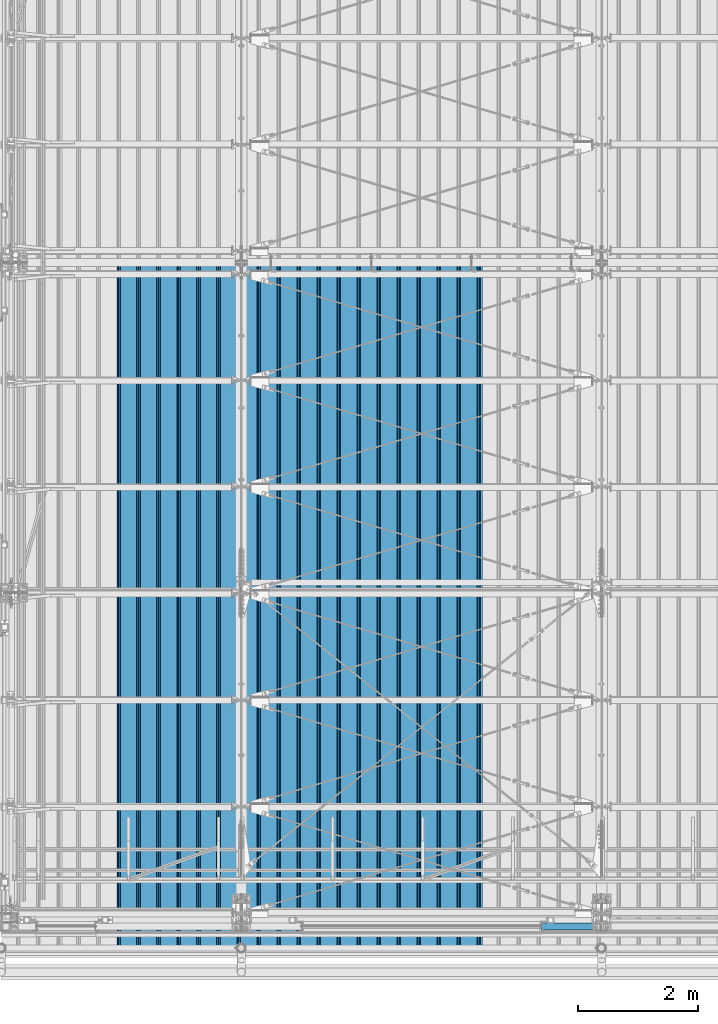
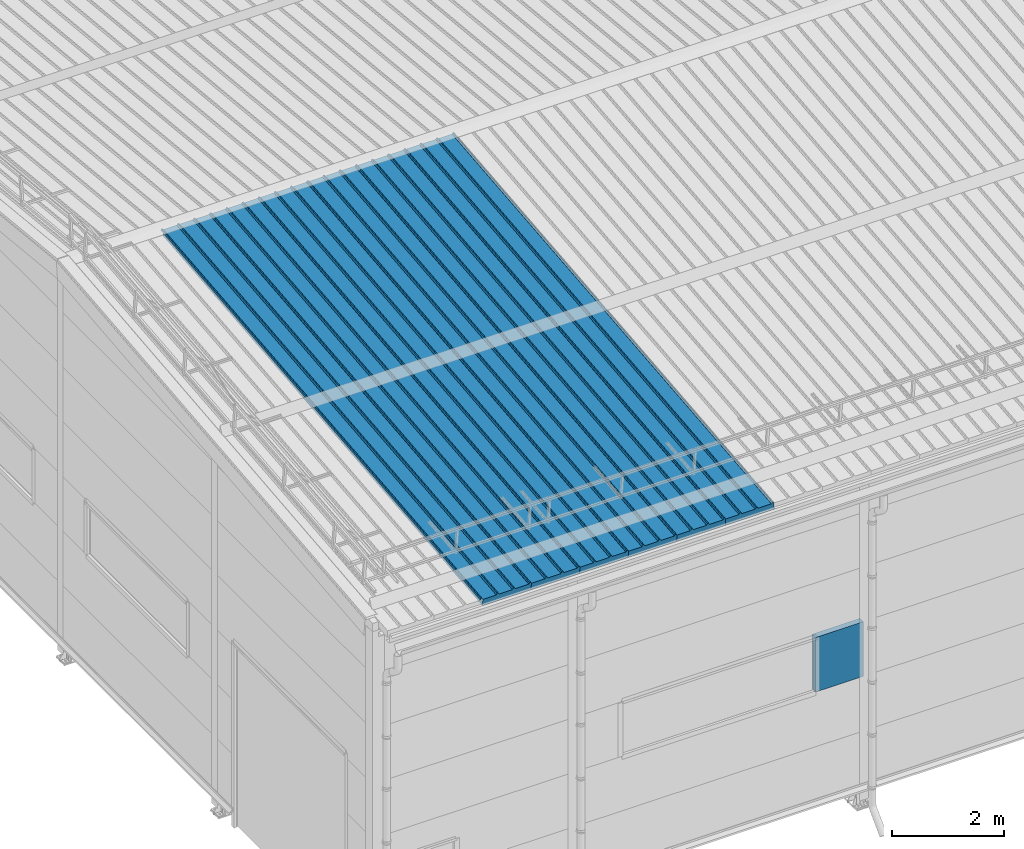
# One storey, part 35 of 709: 7 beams, 7 elements without a shape of their own.
"""IFC4 building model written with IfcOpenShell, lengths in millimetres."""

from ifc_helpers import new_model, si_unit, direction, frame, origin_with_axes, place, context, subcontext, project, spatial, line, indexed_curve, outline, extrude, material, element, aggregate, save


model = new_model("IFC4")

# Units and contexts
model_context = context("Model", 3, precision=0.2, world=origin_with_axes(), true_north=direction((0.0, 1.0)))
body_context = subcontext(model_context, "Body", "Model", "MODEL_VIEW")
ifc_project = project(units=[si_unit("LENGTHUNIT", "METRE", prefix="MILLI"), si_unit("AREAUNIT", "SQUARE_METRE"), si_unit("VOLUMEUNIT", "CUBIC_METRE"), si_unit("MASSUNIT", "GRAM", prefix="KILO"), si_unit("TIMEUNIT", "SECOND"), si_unit("PLANEANGLEUNIT", "RADIAN"), si_unit("SOLIDANGLEUNIT", "STERADIAN"), si_unit("THERMODYNAMICTEMPERATUREUNIT", "DEGREE_CELSIUS"), si_unit("LUMINOUSINTENSITYUNIT", "LUMEN")], contexts=[model_context])

# Site, building, storey
site_placement = place(None, origin_with_axes())
site = spatial("IfcSite", under=ifc_project, at=site_placement, CompositionType="ELEMENT")
building_placement = place(site_placement, origin_with_axes())
building = spatial("IfcBuilding", under=site, at=building_placement, Name="Undefined", CompositionType="ELEMENT")
storey_placement = place(building_placement, origin_with_axes())
storey = spatial("IfcBuildingStorey", under=building, at=storey_placement, Name="Undefined", CompositionType="ELEMENT", Elevation=0.0)

# Assembly, beam
assembly_1_placement = place(storey_placement, frame((7452.44, -410.89541, 7279.78979), z_axis=(1.0, 0.0, 0.0), x_axis=(0.0, 0.9950371902, 0.099503719)))
assembly_1 = element("IfcElementAssembly", 1, at=assembly_1_placement, inside=storey)
ifc_material = material(Name="Insulation", Category="Insulation")
beam_1_placement = place(assembly_1_placement, origin_with_axes())
beam_1 = element("IfcBeam", 2, at=beam_1_placement, material=ifc_material, ObjectType="P-99", context=body_context, shape_type="SolidModel", body=[
    extrude(outline(indexed_curve([(-509.8453, 89.5), (-490.1547, 89.5), (-471.67949, 57.5), (-471.67949, -88.5), (-436.67949, -88.5), (-436.67949, -91.5), (562.55841, -91.5), (562.55841, -89.5), (527.55841, -89.5), (527.55841, 57.5), (510.2379, 88.5), (489.7621, 88.5), (472.44159, 58.5), (196.71923, 58.5), (177.66667, 91.5), (155.66667, 91.5), (136.61411, 58.5), (-136.61411, 58.5), (-155.66667, 91.5), (-177.66667, 91.5), (-196.71923, 58.5), (-469.94744, 58.5), (-489.0, 91.5), (-511.0, 91.5), (-527.16581, 63.5), (-525.43376, 62.5)], segments=[line(1, 2, 3, 4, 5, 6, 7, 8, 9, 10, 11, 12, 13, 14, 15, 16, 17, 18, 19, 20, 21, 22, 23, 24, 25, 26, 1)])), frame((0.0, 0.0, 0.0), z_axis=(-1.0, 0.0, 0.0), x_axis=(0.0, 0.0, 1.0)), (0.0, 0.0, -1.0), 11459.0),
])
aggregate(assembly_1, [beam_1])

assembly_2_placement = place(storey_placement, frame((6452.44, -410.89541, 7279.78979), z_axis=(1.0, 0.0, 0.0), x_axis=(0.0, 0.9950371902, 0.099503719)))
assembly_2 = element("IfcElementAssembly", 3, at=assembly_2_placement, inside=storey)
beam_2_placement = place(assembly_2_placement, origin_with_axes())
beam_2 = element("IfcBeam", 4, at=beam_2_placement, material=ifc_material, ObjectType="P-99", context=body_context, shape_type="SolidModel", body=[
    extrude(outline(indexed_curve([(-509.8453, 89.5), (-490.1547, 89.5), (-471.67949, 57.5), (-471.67949, -88.5), (-436.67949, -88.5), (-436.67949, -91.5), (562.55841, -91.5), (562.55841, -89.5), (527.55841, -89.5), (527.55841, 57.5), (510.2379, 88.5), (489.7621, 88.5), (472.44159, 58.5), (196.71923, 58.5), (177.66667, 91.5), (155.66667, 91.5), (136.61411, 58.5), (-136.61411, 58.5), (-155.66667, 91.5), (-177.66667, 91.5), (-196.71923, 58.5), (-469.94744, 58.5), (-489.0, 91.5), (-511.0, 91.5), (-527.16581, 63.5), (-525.43376, 62.5)], segments=[line(1, 2, 3, 4, 5, 6, 7, 8, 9, 10, 11, 12, 13, 14, 15, 16, 17, 18, 19, 20, 21, 22, 23, 24, 25, 26, 1)])), frame((0.0, 0.0, 0.0), z_axis=(-1.0, 0.0, 0.0), x_axis=(0.0, 0.0, 1.0)), (0.0, 0.0, -1.0), 11459.0),
])
aggregate(assembly_2, [beam_2])

assembly_3_placement = place(storey_placement, frame((5452.44, -410.89541, 7279.78979), z_axis=(1.0, 0.0, 0.0), x_axis=(0.0, 0.9950371902, 0.099503719)))
assembly_3 = element("IfcElementAssembly", 5, at=assembly_3_placement, inside=storey)
beam_3_placement = place(assembly_3_placement, origin_with_axes())
beam_3 = element("IfcBeam", 6, at=beam_3_placement, material=ifc_material, ObjectType="P-99", context=body_context, shape_type="SolidModel", body=[
    extrude(outline(indexed_curve([(-509.8453, 89.5), (-490.1547, 89.5), (-471.67949, 57.5), (-471.67949, -88.5), (-436.67949, -88.5), (-436.67949, -91.5), (562.55841, -91.5), (562.55841, -89.5), (527.55841, -89.5), (527.55841, 57.5), (510.2379, 88.5), (489.7621, 88.5), (472.44159, 58.5), (196.71923, 58.5), (177.66667, 91.5), (155.66667, 91.5), (136.61411, 58.5), (-136.61411, 58.5), (-155.66667, 91.5), (-177.66667, 91.5), (-196.71923, 58.5), (-469.94744, 58.5), (-489.0, 91.5), (-511.0, 91.5), (-527.16581, 63.5), (-525.43376, 62.5)], segments=[line(1, 2, 3, 4, 5, 6, 7, 8, 9, 10, 11, 12, 13, 14, 15, 16, 17, 18, 19, 20, 21, 22, 23, 24, 25, 26, 1)])), frame((0.0, 0.0, 0.0), z_axis=(-1.0, 0.0, 0.0), x_axis=(0.0, 0.0, 1.0)), (0.0, 0.0, -1.0), 11459.0),
])
aggregate(assembly_3, [beam_3])

assembly_4_placement = place(storey_placement, frame((4452.44, -410.89541, 7279.78979), z_axis=(1.0, 0.0, 0.0), x_axis=(0.0, 0.9950371902, 0.099503719)))
assembly_4 = element("IfcElementAssembly", 7, at=assembly_4_placement, inside=storey)
beam_4_placement = place(assembly_4_placement, origin_with_axes())
beam_4 = element("IfcBeam", 8, at=beam_4_placement, material=ifc_material, ObjectType="P-99", context=body_context, shape_type="SolidModel", body=[
    extrude(outline(indexed_curve([(-509.8453, 89.5), (-490.1547, 89.5), (-471.67949, 57.5), (-471.67949, -88.5), (-436.67949, -88.5), (-436.67949, -91.5), (562.55841, -91.5), (562.55841, -89.5), (527.55841, -89.5), (527.55841, 57.5), (510.2379, 88.5), (489.7621, 88.5), (472.44159, 58.5), (196.71923, 58.5), (177.66667, 91.5), (155.66667, 91.5), (136.61411, 58.5), (-136.61411, 58.5), (-155.66667, 91.5), (-177.66667, 91.5), (-196.71923, 58.5), (-469.94744, 58.5), (-489.0, 91.5), (-511.0, 91.5), (-527.16581, 63.5), (-525.43376, 62.5)], segments=[line(1, 2, 3, 4, 5, 6, 7, 8, 9, 10, 11, 12, 13, 14, 15, 16, 17, 18, 19, 20, 21, 22, 23, 24, 25, 26, 1)])), frame((0.0, 0.0, 0.0), z_axis=(-1.0, 0.0, 0.0), x_axis=(0.0, 0.0, 1.0)), (0.0, 0.0, -1.0), 11459.0),
])
aggregate(assembly_4, [beam_4])

assembly_5_placement = place(storey_placement, frame((3452.44, -410.89541, 7279.78979), z_axis=(1.0, 0.0, 0.0), x_axis=(0.0, 0.9950371902, 0.099503719)))
assembly_5 = element("IfcElementAssembly", 9, at=assembly_5_placement, inside=storey)
beam_5_placement = place(assembly_5_placement, origin_with_axes())
beam_5 = element("IfcBeam", 10, at=beam_5_placement, material=ifc_material, ObjectType="P-99", context=body_context, shape_type="SolidModel", body=[
    extrude(outline(indexed_curve([(-509.8453, 89.5), (-490.1547, 89.5), (-471.67949, 57.5), (-471.67949, -88.5), (-436.67949, -88.5), (-436.67949, -91.5), (562.55841, -91.5), (562.55841, -89.5), (527.55841, -89.5), (527.55841, 57.5), (510.2379, 88.5), (489.7621, 88.5), (472.44159, 58.5), (196.71923, 58.5), (177.66667, 91.5), (155.66667, 91.5), (136.61411, 58.5), (-136.61411, 58.5), (-155.66667, 91.5), (-177.66667, 91.5), (-196.71923, 58.5), (-469.94744, 58.5), (-489.0, 91.5), (-511.0, 91.5), (-527.16581, 63.5), (-525.43376, 62.5)], segments=[line(1, 2, 3, 4, 5, 6, 7, 8, 9, 10, 11, 12, 13, 14, 15, 16, 17, 18, 19, 20, 21, 22, 23, 24, 25, 26, 1)])), frame((0.0, 0.0, 0.0), z_axis=(-1.0, 0.0, 0.0), x_axis=(0.0, 0.0, 1.0)), (0.0, 0.0, -1.0), 11459.0),
])
aggregate(assembly_5, [beam_5])

assembly_6_placement = place(storey_placement, frame((2452.44, -410.89541, 7279.78979), z_axis=(1.0, 0.0, 0.0), x_axis=(0.0, 0.9950371902, 0.099503719)))
assembly_6 = element("IfcElementAssembly", 11, at=assembly_6_placement, inside=storey)
beam_6_placement = place(assembly_6_placement, origin_with_axes())
beam_6 = element("IfcBeam", 12, at=beam_6_placement, material=ifc_material, ObjectType="P-99", context=body_context, shape_type="SolidModel", body=[
    extrude(outline(indexed_curve([(-509.8453, 89.5), (-490.1547, 89.5), (-471.67949, 57.5), (-471.67949, -88.5), (-436.67949, -88.5), (-436.67949, -91.5), (562.55841, -91.5), (562.55841, -89.5), (527.55841, -89.5), (527.55841, 57.5), (510.2379, 88.5), (489.7621, 88.5), (472.44159, 58.5), (196.71923, 58.5), (177.66667, 91.5), (155.66667, 91.5), (136.61411, 58.5), (-136.61411, 58.5), (-155.66667, 91.5), (-177.66667, 91.5), (-196.71923, 58.5), (-469.94744, 58.5), (-489.0, 91.5), (-511.0, 91.5), (-527.16581, 63.5), (-525.43376, 62.5)], segments=[line(1, 2, 3, 4, 5, 6, 7, 8, 9, 10, 11, 12, 13, 14, 15, 16, 17, 18, 19, 20, 21, 22, 23, 24, 25, 26, 1)])), frame((0.0, 0.0, 0.0), z_axis=(-1.0, 0.0, 0.0), x_axis=(0.0, 0.0, 1.0)), (0.0, 0.0, -1.0), 11459.0),
])
aggregate(assembly_6, [beam_6])

assembly_7_placement = place(storey_placement, frame((9000.0, -60.0, 3275.0), z_axis=(0.0, 0.0, -1.0), x_axis=(1.0, 0.0, 0.0)))
assembly_7 = element("IfcElementAssembly", 13, at=assembly_7_placement, inside=storey)
beam_7_placement = place(assembly_7_placement, origin_with_axes())
beam_7 = element("IfcBeam", 14, at=beam_7_placement, material=ifc_material, ObjectType="P-110", context=body_context, shape_type="SolidModel", body=[
    extrude(outline(indexed_curve([(-595.0, -60.0), (595.0, -60.0), (595.0, 60.0), (-595.0, 60.0)], segments=[line(1, 2, 3, 4, 1)])), frame((0.0, 0.0, 0.0), z_axis=(-1.0, 0.0, 0.0), x_axis=(0.0, 0.0, 1.0)), (0.0, 0.0, -1.0), 990.0),
])
aggregate(assembly_7, [beam_7])

save(model, "model.ifc")
